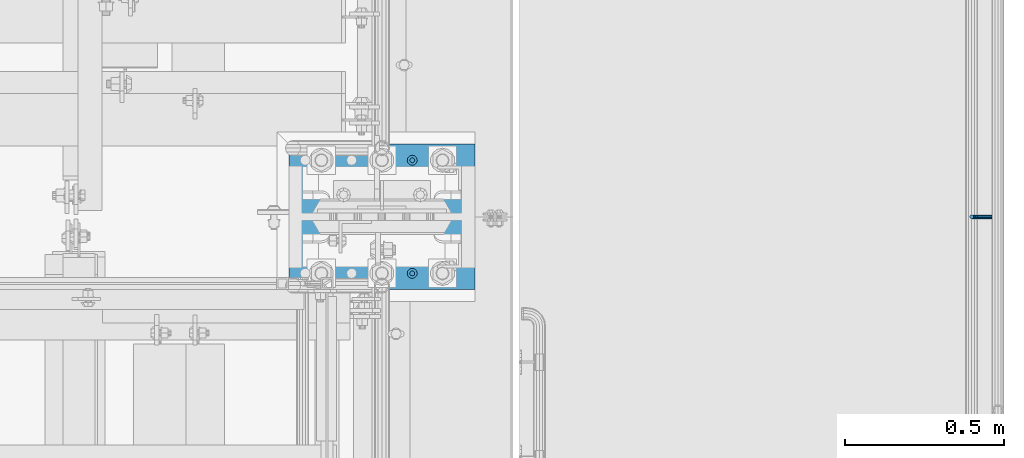
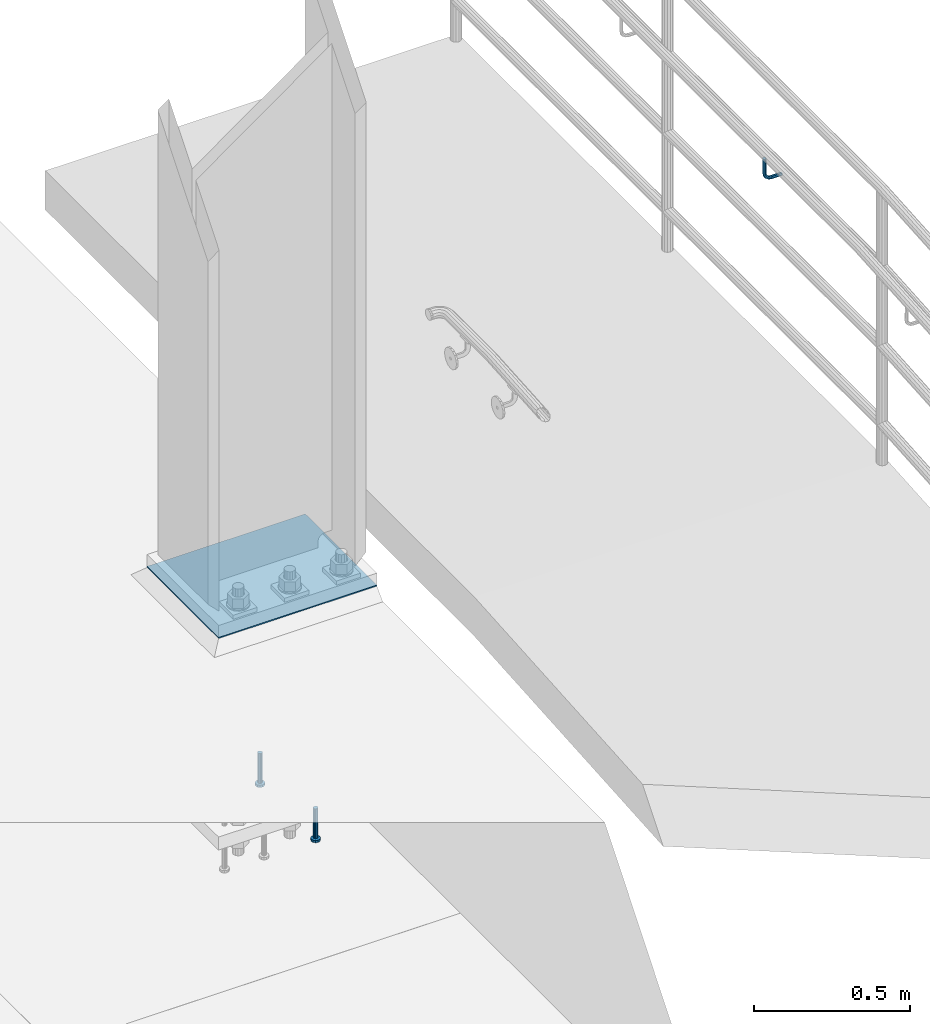
# One storey, part 1221 of 1876: 4 beams, 2 elements without a shape of their own.
"""IFC2X3 building model written with IfcOpenShell, lengths in millimetres."""

from ifc_helpers import new_model, si_unit, frame, origin_with_axes, place, context, subcontext, project, spatial, faceted_brep, material, type_object, element, aggregate, save


model = new_model("IFC2X3")

# Units and contexts
model_context = context("Model", 3, precision=1e-05, world=origin_with_axes())
body_context = subcontext(model_context, "Body", "Model", "MODEL_VIEW")
ifc_project = project(units=[si_unit("LENGTHUNIT", "METRE", prefix="MILLI"), si_unit("AREAUNIT", "SQUARE_METRE"), si_unit("VOLUMEUNIT", "CUBIC_METRE"), si_unit("MASSUNIT", "GRAM", prefix="KILO"), si_unit("TIMEUNIT", "SECOND"), si_unit("PLANEANGLEUNIT", "RADIAN"), si_unit("SOLIDANGLEUNIT", "STERADIAN"), si_unit("THERMODYNAMICTEMPERATUREUNIT", "DEGREE_CELSIUS"), si_unit("LUMINOUSINTENSITYUNIT", "LUMEN")], contexts=[model_context])

# Site, building, storey
site_placement = place(None, origin_with_axes())
site = spatial("IfcSite", under=ifc_project, at=site_placement, CompositionType="ELEMENT")
building_placement = place(site_placement, origin_with_axes())
building = spatial("IfcBuilding", under=site, at=building_placement, Name="Undefined", CompositionType="ELEMENT")
storey_placement = place(building_placement, origin_with_axes())
storey = spatial("IfcBuildingStorey", under=building, at=storey_placement, Name="Undefined", CompositionType="ELEMENT", Elevation=0.0)

# Assembly, beam
assembly_1_placement = place(storey_placement, origin_with_axes())
assembly_1 = element("IfcElementAssembly", 1, at=assembly_1_placement, inside=storey, Name="TEMPLATE", AssemblyPlace="NOTDEFINED", PredefinedType="RIGID_FRAME")
ifc_material_1 = material(Name="STEEL/A36")
beam_type_1 = type_object("IfcBeamType", PredefinedType="NOTDEFINED")
beam_1_placement = place(assembly_1_placement, frame((7912.1, -4572.0, 40.4815), z_axis=(0.0, -1.0, 0.0), x_axis=(-1.0, 0.0, 0.0)))
beam_1 = element("IfcBeam", 2, at=beam_1_placement, type_object=beam_type_1, material=ifc_material_1, Name="TEMPLATE", context=body_context, shape_type="Brep", body=[
    faceted_brep([(9.09494701772928e-13, 2.3815, -228.600000000035), (-9.09494701772928e-13, 2.3815, 228.60000000004), (584.200000000001, 2.3815, 228.6), (584.200000000001, 2.3815, -228.6), (-9.09494701772928e-13, -2.3815, 228.60000000004), (584.200000000001, -2.3815, 228.6), (9.09494701772928e-13, -2.3815, -228.600000000035), (584.200000000001, -2.3815, -228.6)], [[[0, 1, 2, 3]], [[1, 4, 5, 2]], [[4, 6, 7, 5]], [[6, 0, 3, 7]], [[5, 7, 3, 2]], [[6, 4, 1, 0]]]),
])

assembly_2_placement = place(storey_placement, origin_with_axes())
assembly_2 = element("IfcElementAssembly", 3, at=assembly_2_placement, inside=storey, Name="RAIL", AssemblyPlace="NOTDEFINED", PredefinedType="RIGID_FRAME")
beam_type_2 = type_object("IfcBeamType", PredefinedType="NOTDEFINED")
beam_2_placement = place(assembly_2_placement, frame((9537.7001953125, -4572.00009321068, 939.800003052647), z_axis=(0.0, 1.0, 0.0), x_axis=(-1.0, 0.0, 0.0)))
beam_2 = element("IfcBeam", 4, at=beam_2_placement, type_object=beam_type_2, material=ifc_material_1, Name="BRACKET", context=body_context, shape_type="Brep", body=[
    faceted_brep([(0.0, -6.35000000000036, 0.0), (0.0, -4.49012806053463, -4.49012806053452), (38.1000003814697, -4.49012806053463, -4.49012806053452), (38.1000003814697, -6.35000000000002, 0.0), (0.0, 0.0, -6.34999999999991), (38.1000003814697, 0.0, -6.34999999999991), (0.0, 4.49012806053463, -4.49012806053452), (38.1000003814697, 4.49012806053463, -4.49012806053452), (0.0, 6.35000000000036, 0.0), (38.1000003814697, 6.35000000000002, 0.0), (0.0, 4.49012806053463, 4.49012806053452), (38.1000003814697, 4.49012806053463, 4.49012806053452), (0.0, 0.0, 6.34999999999991), (38.1000003814697, 0.0, 6.34999999999991), (0.0, -4.49012806053463, 4.49012806053452), (38.1000003814697, -4.49012806053463, 4.49012806053452), (50.2501992130801, -3.93317518627066, 0.0), (49.5384570355254, -2.21487756830652, 4.49012806053452), (47.8201594175607, 1.93345984517589, 6.34999999999991), (46.1018617995978, 6.08179725865841, 4.49012806053452), (45.3901196220431, 7.80009487662255, 0.0), (46.1018617995978, 6.08179725865841, -4.49012806053452), (47.8201594175607, 1.93345984517589, -6.34999999999991), (49.5384570355254, -2.21487756830652, -4.49012806053452), (59.2355123538691, 4.26448764613235, -4.49012806053452), (60.5506404144035, 2.9493595855979, 0.0), (56.060512353868, 7.43948764613231, -6.34999999999991), (52.8855123538688, 10.6144876461323, -4.49012806053452), (51.5703842933344, 11.9296157066667, 0.0), (52.8855123538688, 10.6144876461323, 4.49012806053452), (56.060512353868, 7.43948764613231, 6.34999999999991), (59.2355123538691, 4.26448764613235, 4.49012806053452), (65.7148775683072, 13.9615429644757, -4.49012806053452), (67.4331751862719, 13.2498007869216, 0.0), (61.5665401548249, 15.6798405824397, -6.34999999999991), (57.4182027413426, 17.3981382004039, -4.49012806053452), (55.6999051233779, 18.1098803779579, 0.0), (57.4182027413426, 17.3981382004039, 4.49012806053452), (61.5665401548249, 15.6798405824397, 6.34999999999991), (65.7148775683072, 13.9615429644757, 4.49012806053452), (67.9901280605336, 25.3999996185304, -4.49012806053452), (69.8500000000004, 25.3999996185303, 0.0), (63.5, 25.3999996185303, -6.34999999999991), (59.0098719394646, 25.3999996185303, -4.49012806053452), (57.1499999999996, 25.3999996185303, 0.0), (59.0098719394646, 25.3999996185303, 4.49012806053452), (63.5, 25.3999996185303, 6.34999999999991), (67.9901280605336, 25.3999996185304, 4.49012806053452), (67.9901280605354, 82.5500030517578, -4.49012806053452), (69.8500000000004, 82.5500030517578, 0.0), (63.5, 82.5500030517578, -6.34999999999991), (59.0098719394646, 82.5500030517578, -4.49012806053452), (57.1499999999996, 82.5500030517578, 0.0), (59.0098719394646, 82.5500030517578, 4.49012806053452), (63.5, 82.5500030517578, 6.34999999999991), (67.9901280605354, 82.5500030517578, 4.49012806053452)], [[[0, 1, 2, 3]], [[1, 4, 5, 2]], [[4, 6, 7, 5]], [[6, 8, 9, 7]], [[8, 10, 11, 9]], [[10, 12, 13, 11]], [[12, 14, 15, 13]], [[14, 0, 3, 15]], [[14, 12, 10, 8, 6, 4, 1, 0]], [[15, 3, 16, 17]], [[13, 15, 17, 18]], [[11, 13, 18, 19]], [[9, 11, 19, 20]], [[7, 9, 20, 21]], [[5, 7, 21, 22]], [[2, 5, 22, 23]], [[3, 2, 23, 16]], [[23, 24, 25, 16]], [[22, 26, 24, 23]], [[21, 27, 26, 22]], [[20, 28, 27, 21]], [[19, 29, 28, 20]], [[18, 30, 29, 19]], [[17, 31, 30, 18]], [[16, 25, 31, 17]], [[24, 32, 33, 25]], [[26, 34, 32, 24]], [[27, 35, 34, 26]], [[28, 36, 35, 27]], [[29, 37, 36, 28]], [[30, 38, 37, 29]], [[31, 39, 38, 30]], [[25, 33, 39, 31]], [[32, 40, 41, 33]], [[34, 42, 40, 32]], [[35, 43, 42, 34]], [[36, 44, 43, 35]], [[37, 45, 44, 36]], [[38, 46, 45, 37]], [[39, 47, 46, 38]], [[33, 41, 47, 39]], [[41, 40, 48, 49]], [[40, 42, 50, 48]], [[42, 43, 51, 50]], [[43, 44, 52, 51]], [[44, 45, 53, 52]], [[45, 46, 54, 53]], [[46, 47, 55, 54]], [[47, 41, 49, 55]], [[50, 51, 52, 53, 54, 55, 49, 48]]]),
])
aggregate(assembly_2, [beam_2])

# Beam
ifc_material_2 = material(Name="STEEL/A108")
beam_type_3 = type_object("IfcBeamType", Name="5/8-DIA_HEADED ANCHOR STUD", PredefinedType="NOTDEFINED")
beam_3_placement = place(assembly_1_placement, frame((7715.25, -4394.2, -787.4), z_axis=(1.0, 0.0, 0.0), x_axis=(0.0, 0.0, -1.0)))
beam_3 = element("IfcBeam", 5, at=beam_3_placement, type_object=beam_type_3, material=ifc_material_2, Name="HEADED ANCHOR STUD", ObjectType="5/8-DIA_HEADED ANCHOR STUD", context=body_context, shape_type="Brep", body=[
    faceted_brep([(0.0, -7.94000005722046, 0.0), (0.0, -6.86999988555908, -3.97000002861023), (116.84, -6.86999988555908, -3.97000002861023), (116.84, -7.94000005722046, 0.0), (0.0, -3.97000002861023, -6.86999988555908), (116.84, -3.97000002861023, -6.86999988555908), (0.0, 0.0, -7.94000005722046), (116.84, 0.0, -7.94000005722046), (0.0, 3.97000002861023, -6.86999988555908), (116.84, 3.97000002861023, -6.86999988555908), (0.0, 6.86999988555908, -3.97000002861023), (116.84, 6.86999988555908, -3.97000002861023), (0.0, 7.94000005722046, 0.0), (116.84, 7.94000005722046, 0.0), (0.0, 6.86999988555908, 3.97000002861023), (116.84, 6.86999988555908, 3.97000002861023), (0.0, 3.97000002861023, 6.86999988555908), (116.84, 3.97000002861023, 6.86999988555908), (0.0, 0.0, 7.94000005722046), (116.84, 0.0, 7.94000005722046), (0.0, -3.97000002861023, 6.86999988555908), (116.84, -3.97000002861023, 6.86999988555908), (0.0, -6.86999988555908, 3.97000002861023), (116.84, -6.86999988555908, 3.97000002861023), (118.11, -13.75, -7.94000005722046), (118.11, -15.8800001144409, 0.0), (118.11, -7.94000005722046, -13.75), (118.11, 0.0, -15.8800001144409), (118.11, 7.94000005722046, -13.75), (118.11, 13.75, -7.94000005722046), (118.11, 15.8800001144409, 0.0), (118.11, 13.75, 7.94000005722046), (118.11, 7.94000005722046, 13.75), (118.11, 0.0, 15.8800001144409), (118.11, -7.94000005722046, 13.75), (118.11, -13.75, 7.94000005722046), (127.0, -13.75, -7.94000005722046), (127.0, -15.8800001144409, 0.0), (127.0, -7.94000005722046, -13.75), (127.0, 0.0, -15.8800001144409), (127.0, 7.94000005722046, -13.75), (127.0, 13.75, -7.94000005722046), (127.0, 15.8800001144409, 0.0), (127.0, 13.75, 7.94000005722046), (127.0, 7.94000005722046, 13.75), (127.0, 0.0, 15.8800001144409), (127.0, -7.94000005722046, 13.75), (127.0, -13.75, 7.94000005722046)], [[[0, 1, 2, 3]], [[1, 4, 5, 2]], [[4, 6, 7, 5]], [[6, 8, 9, 7]], [[8, 10, 11, 9]], [[10, 12, 13, 11]], [[12, 14, 15, 13]], [[14, 16, 17, 15]], [[16, 18, 19, 17]], [[18, 20, 21, 19]], [[20, 22, 23, 21]], [[22, 0, 3, 23]], [[22, 20, 18, 16, 14, 12, 10, 8, 6, 4, 1, 0]], [[3, 2, 24, 25]], [[2, 5, 26, 24]], [[5, 7, 27, 26]], [[7, 9, 28, 27]], [[9, 11, 29, 28]], [[11, 13, 30, 29]], [[13, 15, 31, 30]], [[15, 17, 32, 31]], [[17, 19, 33, 32]], [[19, 21, 34, 33]], [[21, 23, 35, 34]], [[23, 3, 25, 35]], [[25, 24, 36, 37]], [[24, 26, 38, 36]], [[26, 27, 39, 38]], [[27, 28, 40, 39]], [[28, 29, 41, 40]], [[29, 30, 42, 41]], [[30, 31, 43, 42]], [[31, 32, 44, 43]], [[32, 33, 45, 44]], [[33, 34, 46, 45]], [[34, 35, 47, 46]], [[35, 25, 37, 47]], [[38, 39, 40, 41, 42, 43, 44, 45, 46, 47, 37, 36]]]),
])

beam_4_placement = place(assembly_1_placement, frame((7715.25, -4749.8, -787.4), z_axis=(1.0, 0.0, 0.0), x_axis=(0.0, 0.0, -1.0)))
beam_4 = element("IfcBeam", 6, at=beam_4_placement, type_object=beam_type_3, material=ifc_material_2, Name="HEADED ANCHOR STUD", ObjectType="5/8-DIA_HEADED ANCHOR STUD", context=body_context, shape_type="Brep", body=[
    faceted_brep([(0.0, -7.94000005722046, 0.0), (0.0, -6.86999988555908, -3.97000002861023), (116.84, -6.86999988555908, -3.97000002861023), (116.84, -7.94000005722046, 0.0), (0.0, -3.97000002861023, -6.86999988555908), (116.84, -3.97000002861023, -6.86999988555908), (0.0, 0.0, -7.94000005722046), (116.84, 0.0, -7.94000005722046), (0.0, 3.97000002861023, -6.86999988555908), (116.84, 3.97000002861023, -6.86999988555908), (0.0, 6.86999988555908, -3.97000002861023), (116.84, 6.86999988555908, -3.97000002861023), (0.0, 7.94000005722046, 0.0), (116.84, 7.94000005722046, 0.0), (0.0, 6.86999988555908, 3.97000002861023), (116.84, 6.86999988555908, 3.97000002861023), (0.0, 3.97000002861023, 6.86999988555908), (116.84, 3.97000002861023, 6.86999988555908), (0.0, 0.0, 7.94000005722046), (116.84, 0.0, 7.94000005722046), (0.0, -3.97000002861023, 6.86999988555908), (116.84, -3.97000002861023, 6.86999988555908), (0.0, -6.86999988555908, 3.97000002861023), (116.84, -6.86999988555908, 3.97000002861023), (118.11, -13.75, -7.94000005722046), (118.11, -15.8800001144409, 0.0), (118.11, -7.94000005722046, -13.75), (118.11, 0.0, -15.8800001144409), (118.11, 7.94000005722046, -13.75), (118.11, 13.75, -7.94000005722046), (118.11, 15.8800001144409, 0.0), (118.11, 13.75, 7.94000005722046), (118.11, 7.94000005722046, 13.75), (118.11, 0.0, 15.8800001144409), (118.11, -7.94000005722046, 13.75), (118.11, -13.75, 7.94000005722046), (127.0, -13.75, -7.94000005722046), (127.0, -15.8800001144409, 0.0), (127.0, -7.94000005722046, -13.75), (127.0, 0.0, -15.8800001144409), (127.0, 7.94000005722046, -13.75), (127.0, 13.75, -7.94000005722046), (127.0, 15.8800001144409, 0.0), (127.0, 13.75, 7.94000005722046), (127.0, 7.94000005722046, 13.75), (127.0, 0.0, 15.8800001144409), (127.0, -7.94000005722046, 13.75), (127.0, -13.75, 7.94000005722046)], [[[0, 1, 2, 3]], [[1, 4, 5, 2]], [[4, 6, 7, 5]], [[6, 8, 9, 7]], [[8, 10, 11, 9]], [[10, 12, 13, 11]], [[12, 14, 15, 13]], [[14, 16, 17, 15]], [[16, 18, 19, 17]], [[18, 20, 21, 19]], [[20, 22, 23, 21]], [[22, 0, 3, 23]], [[22, 20, 18, 16, 14, 12, 10, 8, 6, 4, 1, 0]], [[3, 2, 24, 25]], [[2, 5, 26, 24]], [[5, 7, 27, 26]], [[7, 9, 28, 27]], [[9, 11, 29, 28]], [[11, 13, 30, 29]], [[13, 15, 31, 30]], [[15, 17, 32, 31]], [[17, 19, 33, 32]], [[19, 21, 34, 33]], [[21, 23, 35, 34]], [[23, 3, 25, 35]], [[25, 24, 36, 37]], [[24, 26, 38, 36]], [[26, 27, 39, 38]], [[27, 28, 40, 39]], [[28, 29, 41, 40]], [[29, 30, 42, 41]], [[30, 31, 43, 42]], [[31, 32, 44, 43]], [[32, 33, 45, 44]], [[33, 34, 46, 45]], [[34, 35, 47, 46]], [[35, 25, 37, 47]], [[38, 39, 40, 41, 42, 43, 44, 45, 46, 47, 37, 36]]]),
])

aggregate(assembly_1, [beam_3, beam_4, beam_1])

save(model, "model.ifc")
